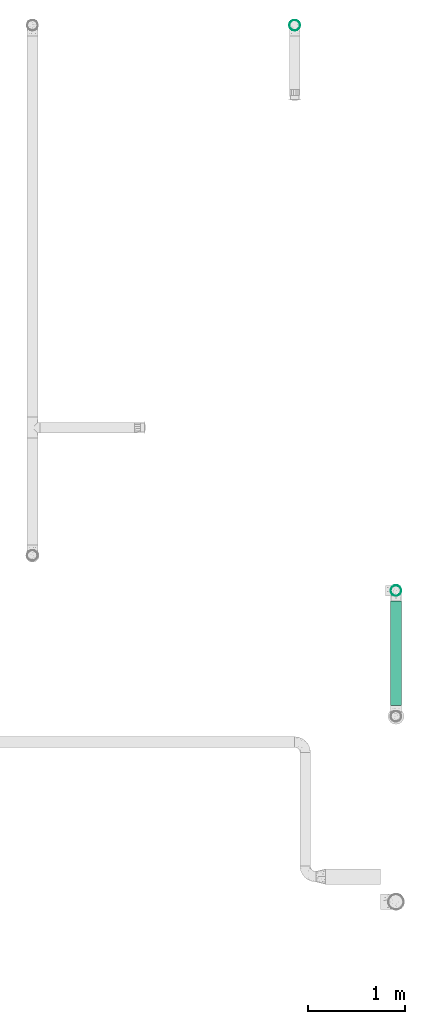
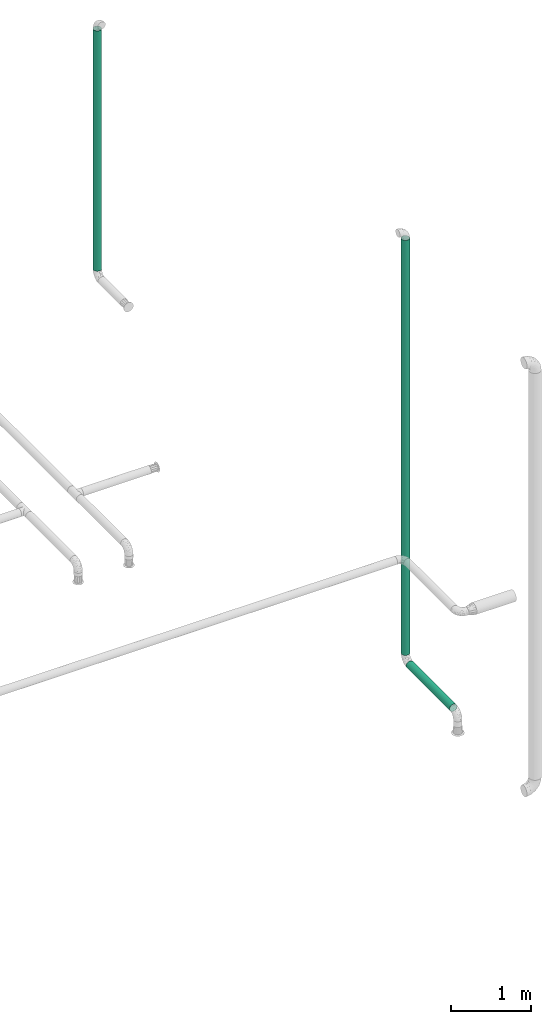
# One storey, part 12 of 115: 3 flow segments.
"""IFC2X3 building model written with IfcOpenShell, lengths in millimetres."""

from ifc_helpers import new_model, entity, si_unit, converted_unit, derived_unit, direction, frame, origin_with_axes, origin_2d_with_axis, place, context, subcontext, project, spatial, hollow_circle, extrude, source, transform, mapped, material, layer, layer_set, layer_usage, type_object, element, save


model = new_model("IFC2X3")

# Units and contexts
model_context = context("Model", 3, precision=1e-05, world=origin_with_axes(), true_north=direction((0.0, 1.0)))
body_context = subcontext(model_context, "Body", "Model", "MODEL_VIEW")
ifc_project = project(units=[si_unit("AREAUNIT", "SQUARE_METRE"), si_unit("VOLUMEUNIT", "CUBIC_METRE", prefix="DECI"), si_unit("TIMEUNIT", "SECOND"), si_unit("THERMODYNAMICTEMPERATUREUNIT", "DEGREE_CELSIUS"), si_unit("PRESSUREUNIT", "PASCAL"), si_unit("MASSUNIT", "GRAM", prefix="KILO"), si_unit("LENGTHUNIT", "METRE", prefix="MILLI"), si_unit("POWERUNIT", "WATT"), si_unit("ELECTRICCURRENTUNIT", "AMPERE"), si_unit("ELECTRICVOLTAGEUNIT", "VOLT"), derived_unit("VOLUMETRICFLOWRATEUNIT", [(si_unit("VOLUMEUNIT", "CUBIC_METRE", prefix="DECI"), 1), (si_unit("TIMEUNIT", "SECOND"), -1)]), derived_unit("LINEARVELOCITYUNIT", [(si_unit("LENGTHUNIT", "METRE"), 1), (si_unit("TIMEUNIT", "SECOND"), -1)]), derived_unit("MASSDENSITYUNIT", [(si_unit("MASSUNIT", "GRAM", prefix="KILO"), 1), (si_unit("VOLUMEUNIT", "CUBIC_METRE"), -1)]), converted_unit("PLANEANGLEUNIT", "DEGREE", entity("IfcRatioMeasure", 0.01745), si_unit("PLANEANGLEUNIT", "RADIAN"), dimensions=[0, 0, 0, 0, 0, 0, 0])], contexts=[model_context])

# Site, building, storey
site_placement = place(None, origin_with_axes())
site = spatial("IfcSite", under=ifc_project, at=site_placement, CompositionType="ELEMENT")
building_placement = place(site_placement, origin_with_axes())
building = spatial("IfcBuilding", under=site, at=building_placement, Name="mc-building", CompositionType="ELEMENT")
storey_placement = place(building_placement, frame((0.0, 0.0, 2950.0), z_axis=(0.0, 0.0, 1.0), x_axis=(1.0, 0.0, 0.0)))
storey = spatial("IfcBuildingStorey", under=building, at=storey_placement, Name="2. Korrus", CompositionType="ELEMENT", Elevation=2950.0)

# Flow segments
ifc_material = material(Name="FZ1")
ifc_layer = layer(ifc_material, 0.0)
ifc_layer_set = layer_set([ifc_layer], Name="FZ1")
ifc_layer_usage = layer_usage(ifc_layer_set, "AXIS1", "POSITIVE", 0.0)
duct_segment_type = type_object("IfcDuctSegmentType", PredefinedType="RIGIDSEGMENT")
shared_shape_1 = source(origin_with_axes(), body_context, "Body", "SweptSolid", [
    extrude(hollow_circle(Radius=55.0, WallThickness=2.0, at=origin_2d_with_axis()), frame((0.0, 0.0, 0.0), z_axis=(1.0, 0.0, 0.0), x_axis=(0.0, 1.0, 0.0)), (0.0, 0.0, 1.0), 3645.0),
])
flow_segment_1_placement = place(storey_placement, frame((36722.77222, 13663.57591, 2410.0), z_axis=(1.0, 0.0, 0.0), x_axis=(0.0, 0.0, 1.0)))
element("IfcFlowSegment", 1, at=flow_segment_1_placement, inside=storey, type_object=duct_segment_type, material=ifc_layer_usage, context=body_context, shape_type="MappedRepresentation", body=[
    mapped(shared_shape_1, transform((0.0, 0.0, 0.0), scale=1.0)),
])
shared_shape_2 = source(origin_with_axes(), body_context, "Body", "SweptSolid", [
    extrude(hollow_circle(Radius=55.0, WallThickness=2.0, at=origin_2d_with_axis()), frame((0.0, 0.0, 0.0), z_axis=(1.0, 0.0, 0.0), x_axis=(0.0, 1.0, 0.0)), (0.0, 0.0, 1.0), 6295.0),
])
flow_segment_2_placement = place(storey_placement, frame((37769.98441, 7819.73852, 6055.0), z_axis=(-1.0, 0.0, 0.0), x_axis=(0.0, 0.0, -1.0)))
element("IfcFlowSegment", 2, at=flow_segment_2_placement, inside=storey, type_object=duct_segment_type, material=ifc_layer_usage, context=body_context, shape_type="MappedRepresentation", body=[
    mapped(shared_shape_2, transform((0.0, 0.0, 0.0), scale=1.0)),
])
shared_shape_3 = source(origin_with_axes(), body_context, "Body", "SweptSolid", [
    extrude(hollow_circle(Radius=55.0, WallThickness=2.0, at=origin_2d_with_axis()), frame((0.0, 0.0, 0.0), z_axis=(1.0, 0.0, 0.0), x_axis=(0.0, 1.0, 0.0)), (0.0, 0.0, 1.0), 1080.0),
])
flow_segment_3_placement = place(storey_placement, frame((37769.98441, 7709.73852, -350.0), z_axis=(0.0, 0.0, 1.0), x_axis=(0.0, -1.0, 0.0)))
element("IfcFlowSegment", 3, at=flow_segment_3_placement, inside=storey, type_object=duct_segment_type, material=ifc_layer_usage, context=body_context, shape_type="MappedRepresentation", body=[
    mapped(shared_shape_3, transform((0.0, 0.0, 0.0), scale=1.0)),
])

save(model, "model.ifc")
